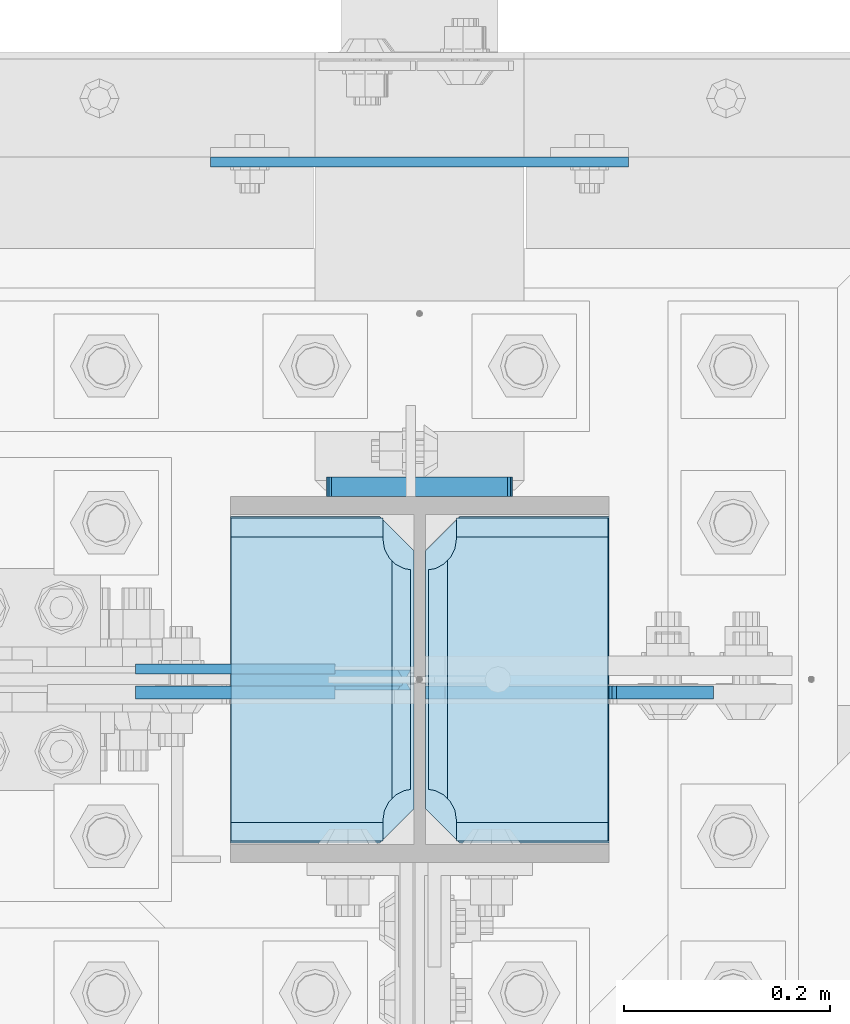
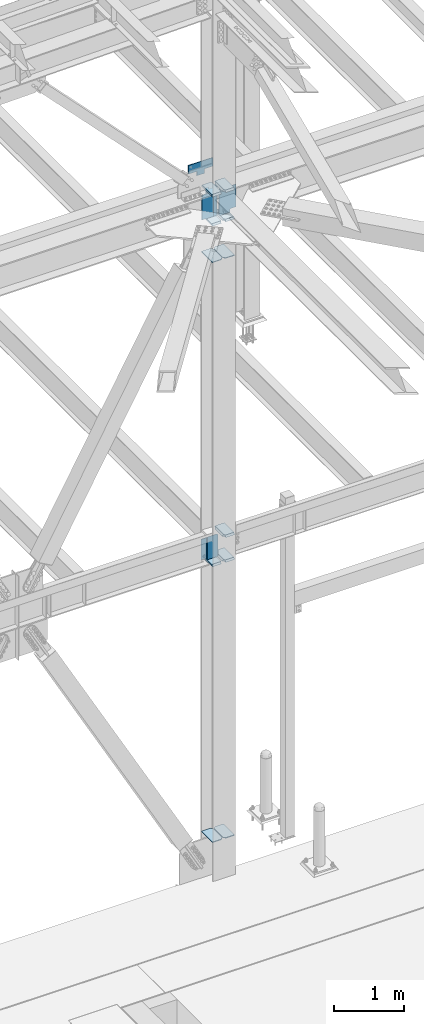
# One storey, part 3494 of 3843: 18 plates, 1 element without a shape of its own.
"""IFC2X3 building model written with IfcOpenShell, lengths in millimetres."""

from ifc_helpers import new_model, si_unit, frame, origin_with_axes, place, context, subcontext, project, spatial, faceted_brep, material, type_object, element, aggregate, save


model = new_model("IFC2X3")

# Units and contexts
model_context = context("Model", 3, precision=1e-05, world=origin_with_axes())
body_context = subcontext(model_context, "Body", "Model", "MODEL_VIEW")
ifc_project = project(units=[si_unit("LENGTHUNIT", "METRE", prefix="MILLI"), si_unit("AREAUNIT", "SQUARE_METRE"), si_unit("VOLUMEUNIT", "CUBIC_METRE"), si_unit("MASSUNIT", "GRAM", prefix="KILO"), si_unit("TIMEUNIT", "SECOND"), si_unit("PLANEANGLEUNIT", "RADIAN"), si_unit("SOLIDANGLEUNIT", "STERADIAN"), si_unit("THERMODYNAMICTEMPERATUREUNIT", "DEGREE_CELSIUS"), si_unit("LUMINOUSINTENSITYUNIT", "LUMEN")], contexts=[model_context])

# Site, building, storey
site_placement = place(None, origin_with_axes())
site = spatial("IfcSite", under=ifc_project, at=site_placement, CompositionType="ELEMENT")
building_placement = place(site_placement, origin_with_axes())
building = spatial("IfcBuilding", under=site, at=building_placement, Name="Undefined", CompositionType="ELEMENT")
storey_placement = place(building_placement, origin_with_axes())
storey = spatial("IfcBuildingStorey", under=building, at=storey_placement, Name="Undefined", CompositionType="ELEMENT", Elevation=0.0)

# Assembly, plates
assembly_placement = place(storey_placement, origin_with_axes())
assembly = element("IfcElementAssembly", 1, at=assembly_placement, inside=storey, Name="COLUMN", AssemblyPlace="NOTDEFINED", PredefinedType="RIGID_FRAME")
ifc_material = material(Name="STEEL/A572-50")
plate_type_1 = type_object("IfcPlateType", PredefinedType="NOTDEFINED")
plate_1_placement = place(assembly_placement, frame((62641.95625, 92055.95, 41291.5016232424), z_axis=(1.0, 0.0, 0.0), x_axis=(0.0, 1.0, 0.0)))
plate_1 = element("IfcPlate", 2, at=plate_1_placement, type_object=plate_type_1, material=ifc_material, Name="CB_COL", context=body_context, shape_type="Brep", body=[
    faceted_brep([(0.0, -6.34999999999854, 33.3375015258789), (0.0, -6.34999999999854, 178.59375), (0.0, 6.34999999999854, 178.59375), (0.0, 6.34999999999854, 33.3375015258789), (317.499999999985, -6.34999999999854, 178.59375), (317.499999999985, 6.34999999999854, 178.59375), (317.499999999985, -6.34999999999854, 33.3375015258789), (317.499999999985, 6.34999999999854, 33.3375015258789), (284.162498474107, -6.34999999999854, 0.0), (284.162498474107, 6.34999999999854, 0.0), (33.3375015258789, -6.34999999999854, 0.0), (33.3375015258789, 6.34999999999854, 0.0)], [[[0, 1, 2, 3]], [[1, 4, 5, 2]], [[4, 6, 7, 5]], [[6, 8, 9, 7]], [[8, 10, 11, 9]], [[10, 0, 3, 11]], [[5, 7, 9, 11, 3, 2]], [[10, 8, 6, 4, 1, 0]]]),
])
plate_2_placement = place(assembly_placement, frame((62630.84375, 92055.95, 41291.5016232424), z_axis=(-1.0, 0.0, 0.0), x_axis=(0.0, 1.0, 0.0)))
plate_2 = element("IfcPlate", 3, at=plate_2_placement, type_object=plate_type_1, material=ifc_material, Name="CB_COL", context=body_context, shape_type="Brep", body=[
    faceted_brep([(0.0, -6.34999999999854, 33.3375015258789), (0.0, -6.34999999999854, 178.59375), (0.0, 6.34999999999854, 178.59375), (0.0, 6.34999999999854, 33.3375015258789), (317.499999999985, -6.34999999999854, 178.59375), (317.499999999985, 6.34999999999854, 178.59375), (317.499999999985, -6.34999999999854, 33.3375015258789), (317.499999999985, 6.34999999999854, 33.3375015258789), (284.162498474107, -6.34999999999854, 0.0), (284.162498474107, 6.34999999999854, 0.0), (33.3375015258789, -6.34999999999854, 0.0), (33.3375015258789, 6.34999999999854, 0.0)], [[[0, 1, 2, 3]], [[1, 4, 5, 2]], [[4, 6, 7, 5]], [[6, 8, 9, 7]], [[8, 10, 11, 9]], [[10, 0, 3, 11]], [[5, 7, 9, 11, 3, 2]], [[10, 8, 6, 4, 1, 0]]]),
])
plate_3_placement = place(assembly_placement, frame((62641.95625, 92055.95, 31152.2658089391), z_axis=(1.0, 0.0, 0.0), x_axis=(0.0, 1.0, 0.0)))
plate_3 = element("IfcPlate", 4, at=plate_3_placement, type_object=plate_type_1, material=ifc_material, Name="CB_COL", context=body_context, shape_type="Brep", body=[
    faceted_brep([(0.0, -6.34999999999854, 33.3375015258789), (0.0, -6.34999999999854, 178.59375), (0.0, 6.34999999999854, 178.59375), (0.0, 6.34999999999854, 33.3375015258789), (317.499999999985, -6.34999999999854, 178.59375), (317.499999999985, 6.34999999999854, 178.59375), (317.499999999985, -6.34999999999854, 33.3375015258789), (317.499999999985, 6.34999999999854, 33.3375015258789), (284.162498474107, -6.34999999999854, 0.0), (284.162498474107, 6.34999999999854, 0.0), (33.3375015258789, -6.34999999999854, 0.0), (33.3375015258789, 6.34999999999854, 0.0)], [[[0, 1, 2, 3]], [[1, 4, 5, 2]], [[4, 6, 7, 5]], [[6, 8, 9, 7]], [[8, 10, 11, 9]], [[10, 0, 3, 11]], [[5, 7, 9, 11, 3, 2]], [[10, 8, 6, 4, 1, 0]]]),
])
plate_4_placement = place(assembly_placement, frame((62630.84375, 92055.95, 31152.2658089391), z_axis=(-1.0, 0.0, 0.0), x_axis=(0.0, 1.0, 0.0)))
plate_4 = element("IfcPlate", 5, at=plate_4_placement, type_object=plate_type_1, material=ifc_material, Name="CB_COL", context=body_context, shape_type="Brep", body=[
    faceted_brep([(0.0, -6.34999999999854, 33.3375015258789), (0.0, -6.34999999999854, 178.59375), (0.0, 6.34999999999854, 178.59375), (0.0, 6.34999999999854, 33.3375015258789), (317.499999999985, -6.34999999999854, 178.59375), (317.499999999985, 6.34999999999854, 178.59375), (317.499999999985, -6.34999999999854, 33.3375015258789), (317.499999999985, 6.34999999999854, 33.3375015258789), (284.162498474107, -6.34999999999854, 0.0), (284.162498474107, 6.34999999999854, 0.0), (33.3375015258789, -6.34999999999854, 0.0), (33.3375015258789, 6.34999999999854, 0.0)], [[[0, 1, 2, 3]], [[1, 4, 5, 2]], [[4, 6, 7, 5]], [[6, 8, 9, 7]], [[8, 10, 11, 9]], [[10, 0, 3, 11]], [[5, 7, 9, 11, 3, 2]], [[10, 8, 6, 4, 1, 0]]]),
])
plate_type_2 = type_object("IfcPlateType", PredefinedType="NOTDEFINED")
plate_5_placement = place(assembly_placement, frame((62641.95625, 92375.0375, 41941.75), z_axis=(0.0, -1.0, 0.0), x_axis=(1.0, 0.0, 0.0)))
plate_5 = element("IfcPlate", 6, at=plate_5_placement, type_object=plate_type_2, material=ifc_material, Name="PLATE", context=body_context, shape_type="Brep", body=[
    faceted_brep([(17.7290728964945, 9.33242473992141, 272.460514298873), (21.5063709990791, 15.875, 276.23781240145), (21.5063709990791, 15.875, 44.4371753915184), (17.7290728964945, 9.33242473992868, 48.2144734940957), (9.32072521071677, -5.2314900089259, 52.4987406282016), (3.17549995231093, -15.875, 53.4720486914302), (3.17549995231093, -15.875, 267.202939101539), (9.32072521071677, -5.2314900089259, 268.176247164767), (30.1625003814697, 15.875, 299.168629000924), (30.1625003814697, -15.875, 317.499500047692), (177.799999999999, -15.875, 317.499500047692), (177.799999999999, 15.875, 299.168629000924), (177.799999999999, 15.875, 21.5053709990898), (177.799999999999, -15.875, 3.17449995232164), (30.1625003814697, -15.875, 3.17449995232164), (30.1625003814697, 15.875, 21.5053709990898), (9.32072521071314, -15.875, 268.176259371801), (17.7290728964945, -15.875, 272.460526505907), (24.401975401448, -15.875, 279.133429010864), (24.401975401448, 15.875, 279.133429010864), (28.6862425355503, -15.875, 287.541776696642), (28.6862425355503, 15.875, 287.541776696642), (30.1625003814697, -15.875, 296.862501907352), (30.1625003814697, 15.875, 296.862501907352), (30.1625003814697, -15.875, 23.8124980926514), (30.1625003814697, 15.875, 23.8124980926514), (28.6862425355503, -15.875, 33.1332233033609), (28.6862425355503, 15.875, 33.1332233033609), (24.401975401448, -15.875, 41.5415709891386), (24.401975401448, 15.875, 41.5415709891386), (17.7290728964945, -15.875, 48.2144734940957), (9.32072521071677, -15.875, 52.4987406282016)], [[[0, 1, 2, 3, 4, 5, 6, 7]], [[8, 9, 10, 11]], [[12, 13, 14, 15]], [[16, 7, 6]], [[16, 17, 0, 7]], [[17, 18, 19, 1, 0]], [[18, 20, 21, 19]], [[20, 22, 23, 21]], [[23, 22, 9, 8]], [[13, 12, 11, 10]], [[24, 25, 15, 14]], [[24, 26, 27, 25]], [[26, 28, 29, 27]], [[29, 28, 30, 3, 2]], [[30, 31, 4, 3]], [[31, 5, 4]], [[19, 21, 23, 8, 11, 12, 15, 25, 27, 29, 2, 1]], [[31, 30, 28, 26, 24, 14, 13, 10, 9, 22, 20, 18, 17, 16, 6, 5]]]),
])
plate_6_placement = place(assembly_placement, frame((62641.95625, 92375.0375, 35985.45), z_axis=(0.0, -1.0, 0.0), x_axis=(1.0, 0.0, 0.0)))
plate_6 = element("IfcPlate", 7, at=plate_6_placement, type_object=plate_type_2, material=ifc_material, Name="PLATE", context=body_context, shape_type="Brep", body=[
    faceted_brep([(17.7290728964945, 9.33242473992141, 272.460514298873), (21.5063709990791, 15.875, 276.23781240145), (21.5063709990791, 15.875, 44.4371753915184), (17.7290728964945, 9.33242473992868, 48.2144734940957), (9.32072521071677, -5.2314900089259, 52.4987406282016), (3.17549995231093, -15.875, 53.4720486914302), (3.17549995231093, -15.875, 267.202939101539), (9.32072521071677, -5.2314900089259, 268.176247164767), (30.1625003814697, 15.875, 299.168629000924), (30.1625003814697, -15.875, 317.499500047692), (177.799999999999, -15.875, 317.499500047692), (177.799999999999, 15.875, 299.168629000924), (177.799999999999, 15.875, 21.5053709990898), (177.799999999999, -15.875, 3.17449995232164), (30.1625003814697, -15.875, 3.17449995232164), (30.1625003814697, 15.875, 21.5053709990898), (9.32072521071314, -15.875, 268.176259371801), (17.7290728964945, -15.875, 272.460526505907), (24.401975401448, -15.875, 279.133429010864), (24.401975401448, 15.875, 279.133429010864), (28.6862425355503, -15.875, 287.541776696642), (28.6862425355503, 15.875, 287.541776696642), (30.1625003814697, -15.875, 296.862501907352), (30.1625003814697, 15.875, 296.862501907352), (30.1625003814697, -15.875, 23.8124980926514), (30.1625003814697, 15.875, 23.8124980926514), (28.6862425355503, -15.875, 33.1332233033609), (28.6862425355503, 15.875, 33.1332233033609), (24.401975401448, -15.875, 41.5415709891386), (24.401975401448, 15.875, 41.5415709891386), (17.7290728964945, -15.875, 48.2144734940957), (9.32072521071677, -15.875, 52.4987406282016)], [[[0, 1, 2, 3, 4, 5, 6, 7]], [[8, 9, 10, 11]], [[12, 13, 14, 15]], [[16, 7, 6]], [[16, 17, 0, 7]], [[17, 18, 19, 1, 0]], [[18, 20, 21, 19]], [[20, 22, 23, 21]], [[23, 22, 9, 8]], [[13, 12, 11, 10]], [[24, 25, 15, 14]], [[24, 26, 27, 25]], [[26, 28, 29, 27]], [[29, 28, 30, 3, 2]], [[30, 31, 4, 3]], [[31, 5, 4]], [[19, 21, 23, 8, 11, 12, 15, 25, 27, 29, 2, 1]], [[31, 30, 28, 26, 24, 14, 13, 10, 9, 22, 20, 18, 17, 16, 6, 5]]]),
])
plate_7_placement = place(assembly_placement, frame((62641.95625, 92375.0375, 42452.925), z_axis=(0.0, -1.0, 0.0), x_axis=(1.0, 0.0, 0.0)))
plate_7 = element("IfcPlate", 8, at=plate_7_placement, type_object=plate_type_2, material=ifc_material, Name="PLATE", context=body_context, shape_type="Brep", body=[
    faceted_brep([(17.7290728964945, 9.33263080204051, 272.460514298873), (21.5063709990791, 15.875, 276.23781240145), (21.5063709990791, 15.875, 44.4371753915184), (17.7290728964945, 9.33263080204051, 48.2144734940957), (9.32072521071677, -5.23082524805068, 52.4987406282016), (3.17549995231093, -15.875, 53.4720486914302), (3.17549995231093, -15.875, 267.202939101539), (9.32072521071677, -5.23082524805068, 268.176247164767), (30.1625003814697, 15.875, 299.168629000924), (30.1625003814697, -15.875, 317.499500047692), (177.799999999999, -15.875, 317.499500047692), (177.799999999999, 15.875, 299.168629000924), (177.799999999999, 15.875, 21.5053709990898), (177.799999999999, -15.875, 3.17449995232164), (30.1625003814697, -15.875, 3.17449995232164), (30.1625003814697, 15.875, 21.5053709990898), (9.32072521071314, -15.875, 268.176259371801), (17.7290728964945, -15.875, 272.460526505907), (24.401975401448, -15.875, 279.133429010864), (24.401975401448, 15.875, 279.133429010864), (28.6862425355503, -15.875, 287.541776696642), (28.6862425355503, 15.875, 287.541776696642), (30.1625003814697, -15.875, 296.862501907352), (30.1625003814697, 15.875, 296.862501907352), (30.1625003814697, -15.875, 23.8124980926514), (30.1625003814697, 15.875, 23.8124980926514), (28.6862425355503, -15.875, 33.1332233033609), (28.6862425355503, 15.875, 33.1332233033609), (24.401975401448, -15.875, 41.5415709891386), (24.401975401448, 15.875, 41.5415709891386), (17.7290728964945, -15.875, 48.2144734940957), (9.32072521071677, -15.875, 52.4987406282016)], [[[0, 1, 2, 3, 4, 5, 6, 7]], [[8, 9, 10, 11]], [[12, 13, 14, 15]], [[16, 7, 6]], [[16, 17, 0, 7]], [[17, 18, 19, 1, 0]], [[18, 20, 21, 19]], [[20, 22, 23, 21]], [[23, 22, 9, 8]], [[13, 12, 11, 10]], [[24, 25, 15, 14]], [[24, 26, 27, 25]], [[26, 28, 29, 27]], [[29, 28, 30, 3, 2]], [[30, 31, 4, 3]], [[31, 5, 4]], [[19, 21, 23, 8, 11, 12, 15, 25, 27, 29, 2, 1]], [[31, 30, 28, 26, 24, 14, 13, 10, 9, 22, 20, 18, 17, 16, 6, 5]]]),
])
plate_8_placement = place(assembly_placement, frame((62641.95625, 92375.0375, 36420.425), z_axis=(0.0, -1.0, 0.0), x_axis=(1.0, 0.0, 0.0)))
plate_8 = element("IfcPlate", 9, at=plate_8_placement, type_object=plate_type_2, material=ifc_material, Name="PLATE", context=body_context, shape_type="Brep", body=[
    faceted_brep([(17.7290728964945, 9.33242473992141, 272.460514298873), (21.5063709990791, 15.875, 276.23781240145), (21.5063709990791, 15.875, 44.4371753915184), (17.7290728964945, 9.33242473992868, 48.2144734940957), (9.32072521071677, -5.2314900089259, 52.4987406282016), (3.17549995231093, -15.875, 53.4720486914302), (3.17549995231093, -15.875, 267.202939101539), (9.32072521071677, -5.2314900089259, 268.176247164767), (30.1625003814697, 15.875, 299.168629000924), (30.1625003814697, -15.875, 317.499500047692), (177.799999999999, -15.875, 317.499500047692), (177.799999999999, 15.875, 299.168629000924), (177.799999999999, 15.875, 21.5053709990898), (177.799999999999, -15.875, 3.17449995232164), (30.1625003814697, -15.875, 3.17449995232164), (30.1625003814697, 15.875, 21.5053709990898), (9.32072521071314, -15.875, 268.176259371801), (17.7290728964945, -15.875, 272.460526505907), (24.401975401448, -15.875, 279.133429010864), (24.401975401448, 15.875, 279.133429010864), (28.6862425355503, -15.875, 287.541776696642), (28.6862425355503, 15.875, 287.541776696642), (30.1625003814697, -15.875, 296.862501907352), (30.1625003814697, 15.875, 296.862501907352), (30.1625003814697, -15.875, 23.8124980926514), (30.1625003814697, 15.875, 23.8124980926514), (28.6862425355503, -15.875, 33.1332233033609), (28.6862425355503, 15.875, 33.1332233033609), (24.401975401448, -15.875, 41.5415709891386), (24.401975401448, 15.875, 41.5415709891386), (17.7290728964945, -15.875, 48.2144734940957), (9.32072521071677, -15.875, 52.4987406282016)], [[[0, 1, 2, 3, 4, 5, 6, 7]], [[8, 9, 10, 11]], [[12, 13, 14, 15]], [[16, 7, 6]], [[16, 17, 0, 7]], [[17, 18, 19, 1, 0]], [[18, 20, 21, 19]], [[20, 22, 23, 21]], [[23, 22, 9, 8]], [[13, 12, 11, 10]], [[24, 25, 15, 14]], [[24, 26, 27, 25]], [[26, 28, 29, 27]], [[29, 28, 30, 3, 2]], [[30, 31, 4, 3]], [[31, 5, 4]], [[19, 21, 23, 8, 11, 12, 15, 25, 27, 29, 2, 1]], [[31, 30, 28, 26, 24, 14, 13, 10, 9, 22, 20, 18, 17, 16, 6, 5]]]),
])
plate_9_placement = place(assembly_placement, frame((62453.04375, 92375.0375, 41941.75), z_axis=(0.0, -1.0, 0.0), x_axis=(1.0, 0.0, 0.0)))
plate_9 = element("IfcPlate", 10, at=plate_9_placement, type_object=plate_type_2, material=ifc_material, Name="PLATE", context=body_context, shape_type="Brep", body=[
    faceted_brep([(160.070927103505, 9.33329077896633, 48.2144734940957), (156.294129000915, 15.875, 44.437675391513), (156.294129000915, 15.875, 276.23732460849), (160.070927103505, 9.33329077896633, 272.460526505907), (168.479274789282, -5.23062396988826, 268.176259371801), (174.625000047687, -15.875, 267.202872116366), (174.625000047687, -15.875, 53.4721278836369), (168.479274789282, -5.23062396988826, 52.4987406282016), (147.63749961853, 15.875, 21.5053709990898), (147.63749961853, -15.875, 3.17449995232164), (0.0, -15.875, 3.17449995232164), (0.0, 15.875, 21.5053709990898), (0.0, 15.875, 299.168629000924), (0.0, -15.875, 317.499500047692), (147.63749961853, -15.875, 317.499500047692), (147.63749961853, 15.875, 299.168629000924), (147.63749961853, -15.875, 296.862501907352), (147.63749961853, 15.875, 296.862501907352), (149.113757464445, -15.875, 287.541776696642), (149.113757464445, 15.875, 287.541776696642), (153.398024598548, -15.875, 279.133429010864), (153.398024598548, 15.875, 279.133429010864), (160.070927103505, -15.875, 272.460526505907), (168.479274789282, -15.875, 268.176259371801), (168.479274789282, -15.875, 52.4987406282016), (160.070927103505, -15.875, 48.2144734940957), (153.398024598548, -15.875, 41.5415709891386), (153.398024598548, 15.875, 41.5415709891386), (149.113757464449, -15.875, 33.1332233033609), (149.113757464449, 15.875, 33.1332233033609), (147.63749961853, -15.875, 23.8124980926514), (147.63749961853, 15.875, 23.8124980926514)], [[[0, 1, 2, 3, 4, 5, 6, 7]], [[8, 9, 10, 11]], [[12, 13, 14, 15]], [[13, 12, 11, 10]], [[16, 17, 15, 14]], [[16, 18, 19, 17]], [[18, 20, 21, 19]], [[21, 20, 22, 3, 2]], [[22, 23, 4, 3]], [[23, 5, 4]], [[24, 7, 6]], [[24, 25, 0, 7]], [[25, 26, 27, 1, 0]], [[26, 28, 29, 27]], [[28, 30, 31, 29]], [[31, 30, 9, 8]], [[27, 29, 31, 8, 11, 12, 15, 17, 19, 21, 2, 1]], [[9, 30, 28, 26, 25, 24, 6, 5, 23, 22, 20, 18, 16, 14, 13, 10]]]),
])
plate_10_placement = place(assembly_placement, frame((62453.04375, 92375.0375, 35985.45), z_axis=(0.0, -1.0, 0.0), x_axis=(1.0, 0.0, 0.0)))
plate_10 = element("IfcPlate", 11, at=plate_10_placement, type_object=plate_type_2, material=ifc_material, Name="PLATE", context=body_context, shape_type="Brep", body=[
    faceted_brep([(160.070927103505, 9.33329077896633, 48.2144734940957), (156.294129000915, 15.875, 44.437675391513), (156.294129000915, 15.875, 276.23732460849), (160.070927103505, 9.33329077896633, 272.460526505907), (168.479274789282, -5.23062396988826, 268.176259371801), (174.625000047687, -15.875, 267.202872116366), (174.625000047687, -15.875, 53.4721278836369), (168.479274789282, -5.23062396988826, 52.4987406282016), (147.63749961853, 15.875, 21.5053709990898), (147.63749961853, -15.875, 3.17449995232164), (0.0, -15.875, 3.17449995232164), (0.0, 15.875, 21.5053709990898), (0.0, 15.875, 299.168629000924), (0.0, -15.875, 317.499500047692), (147.63749961853, -15.875, 317.499500047692), (147.63749961853, 15.875, 299.168629000924), (147.63749961853, -15.875, 296.862501907352), (147.63749961853, 15.875, 296.862501907352), (149.113757464445, -15.875, 287.541776696642), (149.113757464445, 15.875, 287.541776696642), (153.398024598548, -15.875, 279.133429010864), (153.398024598548, 15.875, 279.133429010864), (160.070927103505, -15.875, 272.460526505907), (168.479274789282, -15.875, 268.176259371801), (168.479274789282, -15.875, 52.4987406282016), (160.070927103505, -15.875, 48.2144734940957), (153.398024598548, -15.875, 41.5415709891386), (153.398024598548, 15.875, 41.5415709891386), (149.113757464449, -15.875, 33.1332233033609), (149.113757464449, 15.875, 33.1332233033609), (147.63749961853, -15.875, 23.8124980926514), (147.63749961853, 15.875, 23.8124980926514)], [[[0, 1, 2, 3, 4, 5, 6, 7]], [[8, 9, 10, 11]], [[12, 13, 14, 15]], [[13, 12, 11, 10]], [[16, 17, 15, 14]], [[16, 18, 19, 17]], [[18, 20, 21, 19]], [[21, 20, 22, 3, 2]], [[22, 23, 4, 3]], [[23, 5, 4]], [[24, 7, 6]], [[24, 25, 0, 7]], [[25, 26, 27, 1, 0]], [[26, 28, 29, 27]], [[28, 30, 31, 29]], [[31, 30, 9, 8]], [[27, 29, 31, 8, 11, 12, 15, 17, 19, 21, 2, 1]], [[9, 30, 28, 26, 25, 24, 6, 5, 23, 22, 20, 18, 16, 14, 13, 10]]]),
])
plate_11_placement = place(assembly_placement, frame((62453.04375, 92375.0375, 42452.925), z_axis=(0.0, -1.0, 0.0), x_axis=(1.0, 0.0, 0.0)))
plate_11 = element("IfcPlate", 12, at=plate_11_placement, type_object=plate_type_2, material=ifc_material, Name="PLATE", context=body_context, shape_type="Brep", body=[
    faceted_brep([(160.070927103505, 9.33349681380787, 48.2144734940957), (156.294129000915, 15.875, 44.437675391513), (156.294129000915, 15.875, 276.23732460849), (160.070927103505, 9.33349681380787, 272.460526505907), (168.479274789282, -5.2299592362906, 268.176259371801), (174.625000047687, -15.875, 267.202872116366), (174.625000047687, -15.875, 53.4721278836369), (168.479274789282, -5.2299592362906, 52.4987406282016), (147.63749961853, 15.875, 21.5053709990898), (147.63749961853, -15.875, 3.17449995232164), (0.0, -15.875, 3.17449995232164), (0.0, 15.875, 21.5053709990898), (0.0, 15.875, 299.168629000924), (0.0, -15.875, 317.499500047692), (147.63749961853, -15.875, 317.499500047692), (147.63749961853, 15.875, 299.168629000924), (147.63749961853, -15.875, 296.862501907352), (147.63749961853, 15.875, 296.862501907352), (149.113757464445, -15.875, 287.541776696642), (149.113757464445, 15.875, 287.541776696642), (153.398024598548, -15.875, 279.133429010864), (153.398024598548, 15.875, 279.133429010864), (160.070927103505, -15.875, 272.460526505907), (168.479274789282, -15.875, 268.176259371801), (168.479274789282, -15.875, 52.4987406282016), (160.070927103505, -15.875, 48.2144734940957), (153.398024598548, -15.875, 41.5415709891386), (153.398024598548, 15.875, 41.5415709891386), (149.113757464449, -15.875, 33.1332233033609), (149.113757464449, 15.875, 33.1332233033609), (147.63749961853, -15.875, 23.8124980926514), (147.63749961853, 15.875, 23.8124980926514)], [[[0, 1, 2, 3, 4, 5, 6, 7]], [[8, 9, 10, 11]], [[12, 13, 14, 15]], [[13, 12, 11, 10]], [[16, 17, 15, 14]], [[16, 18, 19, 17]], [[18, 20, 21, 19]], [[21, 20, 22, 3, 2]], [[22, 23, 4, 3]], [[23, 5, 4]], [[24, 7, 6]], [[24, 25, 0, 7]], [[25, 26, 27, 1, 0]], [[26, 28, 29, 27]], [[28, 30, 31, 29]], [[31, 30, 9, 8]], [[27, 29, 31, 8, 11, 12, 15, 17, 19, 21, 2, 1]], [[9, 30, 28, 26, 25, 24, 6, 5, 23, 22, 20, 18, 16, 14, 13, 10]]]),
])
plate_type_3 = type_object("IfcPlateType", PredefinedType="NOTDEFINED")
plate_12_placement = place(assembly_placement, frame((62360.175, 92225.01875, 36382.325), z_axis=(0.0, 0.0, -1.0), x_axis=(1.0, 0.0, 0.0)))
plate_12 = element("IfcPlate", 13, at=plate_12_placement, type_object=plate_type_3, material=ifc_material, Name="PLATE", context=body_context, shape_type="Brep", body=[
    faceted_brep([(0.0, -4.76249999999709, 0.0), (0.0, -4.76249999999709, 358.774999999994), (0.0, 4.76249999999709, 358.774999999994), (0.0, 4.76249999999709, 0.0), (193.674999999996, -4.76249999999709, 358.774999999994), (193.674999999996, 4.76249999999709, 358.774999999994), (193.674999999996, -4.76249999999709, 0.0), (193.674999999996, 4.76249999999709, 0.0)], [[[0, 1, 2, 3]], [[1, 4, 5, 2]], [[4, 6, 7, 5]], [[6, 0, 3, 7]], [[5, 7, 3, 2]], [[6, 4, 1, 0]]]),
])
plate_type_4 = type_object("IfcPlateType", PredefinedType="NOTDEFINED")
plate_13_placement = place(assembly_placement, frame((62630.84375, 92212.31875, 36020.374999999), z_axis=(-0.707106781186548, 0.0, 0.707106781186548), x_axis=(-0.707106781186548, 0.0, -0.707106781186548)))
plate_13 = element("IfcPlate", 14, at=plate_13_placement, type_object=plate_type_4, material=ifc_material, Name="PLATE", context=body_context, shape_type="Brep", body=[
    faceted_brep([(13.4703841830633, -7.9375, 3.98162703275011), (-254.200736442363, -7.93750000146974, 271.652747659384), (-258.182363479675, -3.06102270678093, 271.652747658118), (-258.182363479675, 7.9375, 262.672491473404), (4.49012799373304, 7.9375, 0.0), (13.4703841824085, -3.06102271161217, -3.63797880709171e-12), (-136.641890355022, -7.93750004474714, 389.211593746732), (-143.122831964749, 7.9375, 395.692535356477), (-258.18236347966, 7.9375, 280.633003841573), (22.4506403697887, 7.9375, -1.81898940354586e-11), (137.510171880771, 7.93750000091677, 115.059531510957), (131.029230271015, -7.9375, 121.540473120702), (117.304595441034, 7.9375, 135.265107950687), (117.304595441034, -7.9375, 135.265107950687), (-116.182063423548, 7.9375, 368.751766815243), (-116.182063423548, -7.9375, 368.751766815243)], [[[0, 1, 2, 3, 4, 5]], [[6, 7, 8, 2, 1]], [[9, 5, 4]], [[9, 10, 11, 0, 5]], [[12, 13, 11, 10]], [[14, 15, 13, 12]], [[11, 13, 15, 6, 1, 0]], [[8, 3, 2]], [[14, 12, 10, 9, 4, 3, 8, 7]], [[15, 14, 7, 6]]]),
])
plate_type_5 = type_object("IfcPlateType", PredefinedType="NOTDEFINED")
plate_14_placement = place(assembly_placement, frame((62360.175, 92202.0, 42413.2375), z_axis=(0.0, 0.0, -1.0), x_axis=(1.0, 0.0, 0.0)))
plate_14 = element("IfcPlate", 15, at=plate_14_placement, type_object=plate_type_5, material=ifc_material, Name="PLATE", context=body_context, shape_type="Brep", body=[
    faceted_brep([(0.0, -6.3499999046162, 0.0), (0.0, -6.35000000000582, 431.800000000003), (0.0, 6.35000000000582, 431.800000000003), (7.27595761418343e-12, 6.3499999046162, 0.0), (193.674999999996, -6.35000000000582, 431.800000000003), (193.674999999996, 6.35000000000582, 431.800000000003), (193.674999999996, -6.35000000000582, 0.0), (193.674999999996, 6.35000000000582, 0.0)], [[[0, 1, 2, 3]], [[1, 4, 5, 2]], [[4, 6, 7, 5]], [[6, 0, 3, 7]], [[5, 7, 3, 2]], [[6, 4, 1, 0]]]),
])
plate_type_6 = type_object("IfcPlateType", PredefinedType="NOTDEFINED")
plate_15_placement = place(assembly_placement, frame((62630.8437499996, 92216.2875, 41976.675), z_axis=(-0.707106781186548, 0.0, 0.707106781186548), x_axis=(-0.707106781186548, 0.0, -0.707106781186548)))
plate_15 = element("IfcPlate", 16, at=plate_15_placement, type_object=plate_type_6, material=ifc_material, Name="PLATE", context=body_context, shape_type="Brep", body=[
    faceted_brep([(4.48977442465548, -7.9375, 0.0), (-312.06390018767, -7.9375, 316.553674612336), (-312.06390018767, 3.06120072776685, 325.534139011026), (-308.082449934242, 7.9375, 325.534107581119), (13.4702073986555, 7.9375, 3.98145024821861), (13.4702388281585, 3.06120073364582, 1.45519152283669e-11), (-312.06390018767, -7.9375, 334.514540549832), (-197.004368672904, -7.9375, 449.574072064608), (-190.523427061838, 7.9375, 443.093130453524), (131.029230272985, 7.9375, 121.540473118737), (137.510171884061, -7.9375, 115.059531507664), (22.4506403026729, -7.93750001103617, 0.0), (-177.921324252063, -7.9375, 430.491027643751), (-177.921324252063, 7.9375, 430.491027643751), (118.427127456042, -7.9375, 134.142575935628), (118.427127456042, 7.9375, 134.142575935628)], [[[0, 1, 2, 3, 4, 5]], [[6, 7, 8, 3, 2]], [[9, 10, 11, 5, 4]], [[6, 2, 1]], [[12, 13, 8, 7]], [[13, 12, 14, 15]], [[15, 14, 10, 9]], [[8, 13, 15, 9, 4, 3]], [[11, 0, 5]], [[14, 12, 7, 6, 1, 0, 11, 10]]]),
])
plate_type_7 = type_object("IfcPlateType", PredefinedType="NOTDEFINED")
plate_16_placement = place(assembly_placement, frame((62572.9, 92717.9375, 42367.2), z_axis=(0.0, 0.0, 1.0), x_axis=(1.0, 0.0, 0.0)))
plate_16 = element("IfcPlate", 17, at=plate_16_placement, type_object=plate_type_7, material=ifc_material, Name="PLATE", context=body_context, shape_type="Brep", body=[
    faceted_brep([(0.0, -4.76249999999709, 0.0), (-3.49245965480804e-10, -4.76249999999709, 76.1999999999462), (-3.49245965480804e-10, 4.76249999999709, 76.1999999999462), (0.0, 4.76249999999709, 0.0), (-139.699996948242, -4.76249999999709, 76.1999969482422), (-139.699996948242, 4.76249999999709, 76.1999969482422), (-139.699996948242, -4.76249999999709, 228.600006103516), (-139.699996948242, 4.76249999999709, 228.600006103516), (266.700012207031, -4.76249999999709, 228.600006103516), (266.700012207031, 4.76249999999709, 228.600006103516), (266.700012207031, -4.76249999999709, 76.1999969482422), (266.700012207031, 4.76249999999709, 76.1999969482422), (126.999992370605, -4.76249999999709, 76.1999969482422), (126.999992370605, 4.76249999999709, 76.1999969482422), (126.999992370605, -4.76249999999709, 0.0), (126.999992370605, 4.76249999999709, 0.0)], [[[0, 1, 2, 3]], [[1, 4, 5, 2]], [[4, 6, 7, 5]], [[6, 8, 9, 7]], [[8, 10, 11, 9]], [[10, 12, 13, 11]], [[12, 14, 15, 13]], [[14, 0, 3, 15]], [[5, 7, 9, 11, 13, 15, 3, 2]], [[14, 12, 10, 8, 6, 4, 1, 0]]]),
])
plate_type_8 = type_object("IfcPlateType", PredefinedType="NOTDEFINED")
plate_17_placement = place(assembly_placement, frame((62545.9125, 92402.025, 42356.4551879883), z_axis=(1.0, 0.0, 0.0), x_axis=(0.0, 0.0, -1.0)))
plate_17 = element("IfcPlate", 18, at=plate_17_placement, type_object=plate_type_8, material=ifc_material, Name="PLATE", context=body_context, shape_type="Brep", body=[
    faceted_brep([(-8.22591685395256e-13, -9.52499999999854, 7.9375), (0.0, -9.52499999999418, 173.037499999991), (0.0, 9.52499999999418, 173.037499999991), (0.0, 9.52499999999418, 7.9375), (0.604206210693519, -9.52499999999418, 176.075049744395), (0.604206210693519, 9.52499999999418, 176.075049744395), (2.32483992433117, -9.52499999999418, 178.65016007566), (2.32483992433117, 9.52499999999418, 178.65016007566), (4.89995025560347, -9.52499999999418, 180.370793789305), (4.89995025560347, 9.52499999999418, 180.370793789305), (7.9375, -9.52499999999418, 180.974999999991), (7.9375, 9.52499999999418, 180.974999999991), (274.637499999997, -9.52499999999418, 180.974999999991), (274.637499999997, 9.52499999999418, 180.974999999991), (277.675049744394, -9.52499999999418, 180.370793789305), (277.675049744394, 9.52499999999418, 180.370793789305), (280.250160075666, -9.52499999999418, 178.65016007566), (280.250160075666, 9.52499999999418, 178.65016007566), (281.970793789304, -9.52499999999418, 176.075049744395), (281.970793789304, 9.52499999999418, 176.075049744395), (282.574999999997, -9.52499999999418, 173.037499999991), (282.574999999997, 9.52499999999418, 173.037499999991), (282.574999999997, -9.52499999999418, 7.9375), (282.574999999997, 9.52499999999418, 7.9375), (281.970793789304, -9.52499999999418, 4.8999502555962), (281.970793789304, 9.52499999999418, 4.8999502555962), (280.250160075666, -9.52499999999418, 2.32483992433117), (280.250160075666, 9.52499999999418, 2.32483992433117), (277.675049744394, -9.52499999999418, 0.604206210686243), (277.675049744394, 9.52499999999418, 0.604206210686243), (274.637499999997, -9.52499999999418, 0.0), (274.637499999997, 9.52499999999418, 0.0), (7.9375, -9.52499999999854, 0.0), (7.9375, 9.52499999999418, 0.0), (4.8999502555962, -9.52499999999418, 0.604206210693519), (4.8999502555962, 9.52499999999418, 0.604206210693519), (2.32483992433117, -9.52499999999418, 2.32483992433117), (2.32483992433117, 9.52499999999418, 2.32483992433117), (0.604206210686243, -9.52499999999418, 4.89995025560347), (0.604206210686243, 9.52499999999418, 4.89995025560347)], [[[0, 1, 2, 3]], [[1, 4, 5, 2]], [[4, 6, 7, 5]], [[6, 8, 9, 7]], [[8, 10, 11, 9]], [[10, 12, 13, 11]], [[12, 14, 15, 13]], [[14, 16, 17, 15]], [[16, 18, 19, 17]], [[18, 20, 21, 19]], [[20, 22, 23, 21]], [[22, 24, 25, 23]], [[24, 26, 27, 25]], [[26, 28, 29, 27]], [[28, 30, 31, 29]], [[30, 32, 33, 31]], [[32, 34, 35, 33]], [[34, 36, 37, 35]], [[36, 38, 39, 37]], [[38, 0, 3, 39]], [[5, 7, 9, 11, 13, 15, 17, 19, 21, 23, 25, 27, 29, 31, 33, 35, 37, 39, 3, 2]], [[38, 36, 34, 32, 30, 28, 26, 24, 22, 20, 18, 16, 14, 12, 10, 8, 6, 4, 1, 0]]]),
])
plate_type_9 = type_object("IfcPlateType", PredefinedType="NOTDEFINED")
plate_18_placement = place(assembly_placement, frame((62641.95625, 92201.9999999046, 41976.675), z_axis=(0.707106781186548, 0.0, 0.707106781186548), x_axis=(0.707106781186548, 0.0, -0.707106781186548)))
plate_18 = element("IfcPlate", 19, at=plate_18_placement, type_object=plate_type_9, material=ifc_material, Name="PLATE", context=body_context, shape_type="Brep", body=[
    faceted_brep([(0.0, -6.3499999046162, 0.0), (-312.063900185356, -6.35000000000582, 312.063900214343), (-312.063900185356, 6.35000000000582, 312.063900214343), (7.27595761418343e-12, 6.3499999046162, 0.0), (-312.063900205583, -6.35000000000582, 339.004668568785), (-312.063900205583, 6.35000000000582, 339.004668568785), (-199.810698692741, -6.35000000000582, 451.257870081594), (-199.810698692741, 6.35000000000582, 451.257870081594), (-190.830442436865, -6.35000000000582, 442.277613825718), (-190.830442436865, 6.35000000000582, 442.277613825718), (-186.710265968726, -6.35000000000582, 439.524599925237), (-186.710265968726, 6.35000000000582, 439.524599925237), (-181.850186450694, -6.35000000000582, 438.557870002638), (-181.850186450694, 6.35000000000582, 438.557870002638), (-176.990106932659, -6.35000000000582, 439.524599925237), (-176.990106932659, 6.35000000000582, 439.524599925237), (-172.869930464509, -6.35000000000582, 442.277613825703), (-172.869930464509, 6.35000000000582, 442.277613825703), (-109.446871474913, -6.35000000000582, 505.700672815292), (-109.446871474913, 6.35000000000582, 505.700672815292), (168.941068276839, -6.35000000000582, 227.312733063431), (168.941068276839, 6.35000000000582, 227.312733063431), (105.518009287243, -6.35000000000582, 163.889674073842), (105.518009287243, 6.35000000000582, 163.889674073842), (102.764995386762, -6.35000000000582, 159.76949760571), (102.764995386762, 6.35000000000582, 159.76949760571), (101.798265464178, -6.35000000000582, 154.909418087671), (101.798265464178, 6.35000000000582, 154.909418087671), (102.764995386762, -6.35000000000582, 150.049338569632), (102.764995386762, 6.35000000000582, 150.049338569632), (105.518009287232, -6.35000000000582, 145.929162101485), (105.518009287232, 6.35000000000582, 145.929162101485), (139.193969875923, -6.35000000000582, 112.25320151278), (139.193969875923, 6.35000000000582, 112.25320151278), (26.9407683632217, -6.34999999999854, 1.30967237055302e-10), (26.9407683632217, 6.34999999999854, 1.30967237055302e-10)], [[[0, 1, 2, 3]], [[1, 4, 5, 2]], [[4, 6, 7, 5]], [[6, 8, 9, 7]], [[8, 10, 11, 9]], [[10, 12, 13, 11]], [[12, 14, 15, 13]], [[14, 16, 17, 15]], [[16, 18, 19, 17]], [[18, 20, 21, 19]], [[20, 22, 23, 21]], [[22, 24, 25, 23]], [[24, 26, 27, 25]], [[26, 28, 29, 27]], [[28, 30, 31, 29]], [[30, 32, 33, 31]], [[32, 34, 35, 33]], [[34, 0, 3, 35]], [[5, 7, 9, 11, 13, 15, 17, 19, 21, 23, 25, 27, 29, 31, 33, 35, 3, 2]], [[34, 32, 30, 28, 26, 24, 22, 20, 18, 16, 14, 12, 10, 8, 6, 4, 1, 0]]]),
])
aggregate(assembly, [plate_12, plate_13, plate_14, plate_15, plate_17, plate_5, plate_6, plate_7, plate_8, plate_9, plate_1, plate_2, plate_3, plate_4, plate_18, plate_10, plate_11, plate_16])

save(model, "model.ifc")
